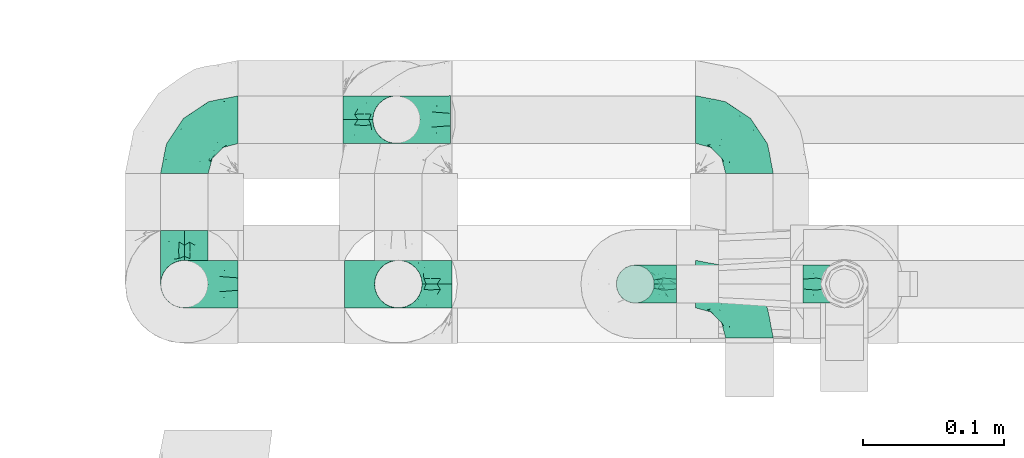
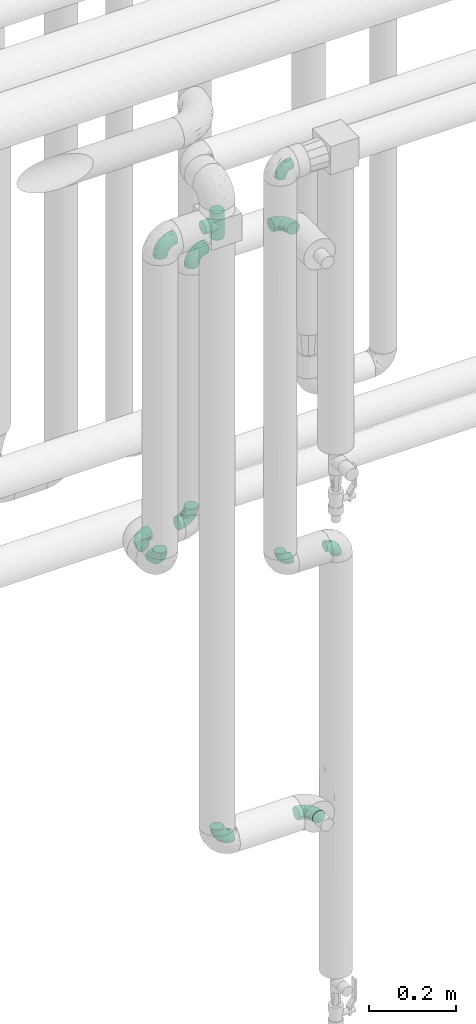
# One storey, part 774 of 827: 12 flow fittings.
"""IFC2X3 building model written with IfcOpenShell, lengths in millimetres."""

from ifc_helpers import new_model, entity, si_unit, converted_unit, derived_unit, direction, frame, origin, place, context, subcontext, project, spatial, faceted_brep, source, transform, mapped, material, type_object, type_shapes, element, save


model = new_model("IFC2X3")

# Units and contexts
model_context = context("Model", 3, precision=0.01, world=origin(), true_north=direction((6.12303176911189e-17, 1.0)))
body_context = subcontext(model_context, "Body", "Model", "MODEL_VIEW")
ifc_project = project(units=[si_unit("LENGTHUNIT", "METRE", prefix="MILLI"), si_unit("AREAUNIT", "SQUARE_METRE"), si_unit("VOLUMEUNIT", "CUBIC_METRE"), converted_unit("PLANEANGLEUNIT", "DEGREE", entity("IfcRatioMeasure", 0.0174532925199433), si_unit("PLANEANGLEUNIT", "RADIAN"), dimensions=[0, 0, 0, 0, 0, 0, 0]), si_unit("MASSUNIT", "GRAM", prefix="KILO"), derived_unit("MASSDENSITYUNIT", [(si_unit("MASSUNIT", "GRAM", prefix="KILO"), 1), (si_unit("LENGTHUNIT", "METRE"), -3)]), derived_unit("MOMENTOFINERTIAUNIT", [(si_unit("LENGTHUNIT", "METRE"), 4)]), si_unit("TIMEUNIT", "SECOND"), si_unit("FREQUENCYUNIT", "HERTZ"), si_unit("THERMODYNAMICTEMPERATUREUNIT", "DEGREE_CELSIUS"), derived_unit("THERMALTRANSMITTANCEUNIT", [(si_unit("MASSUNIT", "GRAM", prefix="KILO"), 1), (si_unit("THERMODYNAMICTEMPERATUREUNIT", "KELVIN"), -1), (si_unit("TIMEUNIT", "SECOND"), -3)]), derived_unit("VOLUMETRICFLOWRATEUNIT", [(si_unit("LENGTHUNIT", "METRE"), 3), (si_unit("TIMEUNIT", "SECOND"), -1)]), derived_unit("MASSFLOWRATEUNIT", [(si_unit("MASSUNIT", "GRAM", prefix="KILO"), 1), (si_unit("TIMEUNIT", "SECOND"), -1)]), derived_unit("ROTATIONALFREQUENCYUNIT", [(si_unit("TIMEUNIT", "SECOND"), -1)]), si_unit("ELECTRICCURRENTUNIT", "AMPERE"), si_unit("ELECTRICVOLTAGEUNIT", "VOLT"), si_unit("POWERUNIT", "WATT"), si_unit("FORCEUNIT", "NEWTON", prefix="KILO"), si_unit("ILLUMINANCEUNIT", "LUX"), si_unit("LUMINOUSFLUXUNIT", "LUMEN"), si_unit("LUMINOUSINTENSITYUNIT", "CANDELA"), derived_unit("USERDEFINED", [(si_unit("MASSUNIT", "GRAM", prefix="KILO"), -1), (si_unit("LENGTHUNIT", "METRE"), -2), (si_unit("TIMEUNIT", "SECOND"), 3), (si_unit("LUMINOUSFLUXUNIT", "LUMEN"), 1)]), derived_unit("LINEARVELOCITYUNIT", [(si_unit("LENGTHUNIT", "METRE"), 1), (si_unit("TIMEUNIT", "SECOND"), -1)]), si_unit("PRESSUREUNIT", "PASCAL"), derived_unit("USERDEFINED", [(si_unit("LENGTHUNIT", "METRE"), -2), (si_unit("MASSUNIT", "GRAM", prefix="KILO"), 1), (si_unit("TIMEUNIT", "SECOND"), -2)]), derived_unit("LINEARFORCEUNIT", [(si_unit("MASSUNIT", "GRAM", prefix="KILO"), 1), (si_unit("LENGTHUNIT", "METRE"), 1), (si_unit("TIMEUNIT", "SECOND"), -2), (si_unit("LENGTHUNIT", "METRE"), -1)]), derived_unit("PLANARFORCEUNIT", [(si_unit("MASSUNIT", "GRAM", prefix="KILO"), 1), (si_unit("LENGTHUNIT", "METRE"), 1), (si_unit("TIMEUNIT", "SECOND"), -2), (si_unit("LENGTHUNIT", "METRE"), -2)])], contexts=[model_context])

# Site, building, storey
site_placement = place(None, origin())
site = spatial("IfcSite", under=ifc_project, at=site_placement, CompositionType="ELEMENT")
building_placement = place(site_placement, origin())
building = spatial("IfcBuilding", under=site, at=building_placement, CompositionType="ELEMENT")
storey_placement = place(building_placement, frame((0.0, 0.0, 28200.0)))
storey = spatial("IfcBuildingStorey", under=building, at=storey_placement, Name="08", CompositionType="ELEMENT", Elevation=28200.0)

# Flow fittings
ifc_material = material()
pipe_fitting_type_1 = type_object("IfcPipeFittingType", Name="ADSK_1", PredefinedType="NOTDEFINED", material=ifc_material)
shared_shape_1 = source(origin(), body_context, "Body", "Brep", [
    faceted_brep([(-38.0, 0.0, -16.85), (-38.0, -4.36, -16.28), (-38.0, -8.43, -14.59), (-38.0, -11.91, -11.91), (-38.0, -14.59, -8.43), (-38.0, -16.28, -4.36), (-38.0, -16.85, 0.0), (-38.0, -16.28, 4.36), (-38.0, -14.59, 8.42), (-38.0, -11.91, 11.91), (-38.0, -8.43, 14.59), (-38.0, -4.36, 16.28), (-38.0, 0.0, 16.85), (-38.0, 4.36, 16.28), (-38.0, 8.42, 14.59), (-38.0, 11.91, 11.91), (-38.0, 14.59, 8.42), (-38.0, 16.28, 4.36), (-38.0, 16.85, 0.0), (-38.0, 16.28, -4.36), (-38.0, 14.59, -8.43), (-38.0, 11.91, -11.91), (-38.0, 8.42, -14.59), (-38.0, 4.36, -16.28), (-4.36, 38.0, -16.28), (-8.42, 38.0, -14.59), (-11.91, 38.0, -11.91), (-14.59, 38.0, -8.43), (-16.28, 38.0, -4.36), (-16.85, 38.0, 0.0), (-16.28, 38.0, 4.36), (-14.59, 38.0, 8.42), (-11.91, 38.0, 11.91), (-8.42, 38.0, 14.59), (-4.36, 38.0, 16.28), (0.0, 38.0, 16.85), (4.36, 38.0, 16.28), (8.43, 38.0, 14.59), (11.91, 38.0, 11.91), (14.59, 38.0, 8.42), (16.28, 38.0, 4.36), (16.85, 38.0, 0.0), (16.28, 38.0, -4.36), (14.59, 38.0, -8.43), (11.91, 38.0, -11.91), (8.43, 38.0, -14.59), (4.36, 38.0, -16.28), (0.0, 38.0, -16.85), (-27.9, -12.9, 9.54), (-27.5, -14.76, 0.0), (-16.53, -9.86, 8.66), (-24.93, -9.38, 12.63), (-29.29, -2.05, 16.58), (-26.82, 2.86, 16.81), (-25.18, -14.43, 5.37), (-4.54, 4.54, 14.04), (-15.36, -3.29, 14.19), (-7.56, -2.74, 10.9), (-28.06, -6.15, 15.21), (9.38, 24.93, 12.63), (-4.71, -4.42, 5.51), (-14.62, -10.99, 4.34), (-8.11, -6.73, 0.0), (-19.46, 0.42, 16.39), (-29.52, 14.25, 10.97), (-26.45, 18.14, 7.62), (-32.84, 15.94, 6.96), (-23.39, 16.22, 12.05), (-11.89, 8.53, 16.79), (-5.59, 13.42, 16.64), (-6.64, 18.62, 16.81), (-32.37, 10.35, 13.72), (-6.4, 32.67, 15.76), (-2.55, 28.48, 16.8), (6.81, 15.56, 11.71), (3.29, 15.36, 14.19), (-29.89, 18.0, 3.79), (-29.34, 6.81, 15.88), (-10.26, 4.27, 15.87), (-2.97, 11.0, 15.66), (2.45, 6.84, 10.65), (-1.8, -0.14, 8.44), (5.0, 5.5, 5.57), (-17.68, 27.4, 7.52), (14.43, 25.18, 5.37), (12.9, 27.9, 9.54), (9.86, 16.53, 8.66), (6.15, 28.06, 15.21), (-17.01, -12.67, 0.0), (2.05, 29.29, 16.58), (14.76, 27.5, 0.0), (10.99, 14.62, 4.34), (12.67, 17.01, 0.0), (-15.84, -6.82, 11.83), (-7.71, 25.61, 16.01), (-22.69, 22.69, 4.1), (-19.68, 27.42, 0.0), (-27.42, 19.68, 0.0), (-18.11, 29.67, 3.72), (-10.87, 29.33, 13.9), (-20.83, 21.64, 8.95), (-18.54, 20.86, 11.76), (-14.08, 30.19, 10.92), (-13.69, 20.27, 14.88), (-20.85, 7.92, 16.51), (-19.04, 4.79, 16.85), (-19.82, 12.26, 15.55), (-19.27, 16.43, 13.96), (-10.72, 19.56, 16.07), (-0.42, 19.46, 16.39), (-25.32, 12.08, 14.15), (-9.04, -6.0, 8.28), (-13.94, 13.94, 16.38), (0.78, -0.78, 0.0), (6.73, 8.11, 0.0), (-9.04, -6.0, -8.28), (-15.9, -7.04, -11.65), (-7.56, -2.74, -10.9), (6.15, 28.06, -15.21), (3.29, 15.36, -14.19), (-0.42, 19.46, -16.39), (-30.19, 14.08, -10.92), (-29.33, 10.87, -13.9), (-25.61, 7.71, -16.01), (-32.67, 6.4, -15.76), (-29.67, 18.11, -3.72), (-18.14, 26.45, -7.62), (-22.69, 22.69, -4.1), (-18.0, 29.89, -3.79), (-25.18, -14.43, -5.37), (-14.62, -10.99, -4.34), (-20.27, 13.69, -14.88), (-15.36, -3.29, -14.19), (-14.25, 29.52, -10.97), (-15.94, 32.84, -6.96), (-24.93, -9.38, -12.63), (-27.9, -12.9, -9.54), (6.81, 15.56, -11.71), (9.38, 24.93, -12.63), (-7.92, 20.85, -16.51), (-4.79, 19.04, -16.85), (-8.53, 11.89, -16.79), (-29.29, -2.05, -16.58), (-13.42, 5.59, -16.64), (-4.27, 10.26, -15.87), (-11.0, 2.97, -15.66), (-16.53, -9.86, -8.66), (-28.48, 2.55, -16.8), (-18.62, 6.64, -16.81), (10.99, 14.62, -4.34), (14.43, 25.18, -5.37), (-12.26, 19.82, -15.55), (-16.43, 19.27, -13.96), (12.9, 27.9, -9.54), (-10.35, 32.37, -13.72), (-6.81, 29.34, -15.88), (2.05, 29.29, -16.58), (-2.86, 26.82, -16.81), (-27.4, 17.68, -7.52), (5.0, 5.5, -5.57), (-16.22, 23.39, -12.05), (-28.06, -6.15, -15.21), (9.86, 16.53, -8.66), (-20.86, 18.54, -11.76), (-21.64, 20.83, -8.95), (-19.56, 10.72, -16.07), (-19.46, 0.42, -16.39), (-12.08, 25.32, -14.15), (-4.54, 4.54, -14.04), (-13.94, 13.94, -16.38), (2.45, 6.84, -10.65), (-4.71, -4.42, -5.51), (-1.8, -0.14, -8.44)], [[[0, 1, 2, 3, 4, 5, 6, 7, 8, 9, 10, 11, 12, 13, 14, 15, 16, 17, 18, 19, 20, 21, 22, 23]], [[24, 25, 26, 27, 28, 29, 30, 31, 32, 33, 34, 35, 36, 37, 38, 39, 40, 41, 42, 43, 44, 45, 46, 47]], [[8, 48, 9]], [[7, 6, 49]], [[48, 50, 51]], [[12, 52, 53]], [[8, 54, 48]], [[7, 54, 8]], [[55, 56, 57]], [[51, 10, 9]], [[51, 58, 10]], [[59, 38, 37]], [[60, 61, 62]], [[58, 56, 63]], [[64, 65, 66]], [[67, 65, 64]], [[68, 69, 70]], [[14, 71, 15]], [[11, 52, 12]], [[34, 72, 73]], [[12, 53, 13]], [[15, 64, 16]], [[74, 59, 75]], [[18, 17, 76]], [[66, 17, 16]], [[77, 13, 53]], [[13, 77, 14]], [[69, 78, 79]], [[80, 81, 82]], [[31, 30, 83]], [[84, 85, 86]], [[59, 87, 75]], [[61, 54, 88]], [[35, 89, 36]], [[84, 40, 39]], [[35, 34, 73]], [[90, 40, 84]], [[39, 38, 85]], [[10, 58, 11]], [[85, 84, 39]], [[91, 84, 86]], [[84, 92, 90]], [[87, 37, 36]], [[93, 56, 51]], [[94, 70, 73]], [[95, 96, 97]], [[84, 91, 92]], [[96, 98, 29]], [[33, 32, 99]], [[76, 95, 97]], [[100, 101, 83]], [[102, 99, 32]], [[65, 95, 76]], [[103, 94, 99]], [[95, 98, 96]], [[72, 99, 94]], [[72, 34, 33]], [[101, 99, 102]], [[7, 49, 54]], [[87, 59, 37]], [[104, 105, 68]], [[106, 103, 107]], [[106, 77, 104]], [[32, 31, 102]], [[94, 103, 108]], [[94, 108, 70]], [[89, 73, 109]], [[71, 64, 15]], [[110, 107, 67]], [[50, 48, 54]], [[51, 9, 48]], [[56, 58, 51]], [[88, 54, 49]], [[52, 58, 63]], [[50, 111, 93]], [[56, 55, 78]], [[38, 59, 85]], [[86, 85, 59]], [[89, 87, 36]], [[41, 40, 90]], [[109, 79, 75]], [[109, 75, 87]], [[75, 55, 80]], [[104, 77, 53]], [[71, 77, 110]], [[31, 83, 102]], [[101, 102, 83]], [[99, 101, 103]], [[106, 107, 110]], [[68, 70, 112]], [[109, 73, 70]], [[68, 112, 104]], [[68, 63, 78]], [[57, 93, 111]], [[80, 55, 57]], [[61, 50, 54]], [[80, 82, 86]], [[81, 57, 111]], [[74, 86, 59]], [[60, 113, 82]], [[82, 114, 91]], [[100, 95, 65]], [[98, 95, 83]], [[73, 89, 35]], [[87, 89, 109]], [[58, 52, 11]], [[53, 52, 63]], [[104, 53, 105]], [[106, 104, 112]], [[18, 76, 97]], [[76, 17, 66]], [[103, 106, 112]], [[77, 106, 110]], [[103, 101, 107]], [[67, 107, 101]], [[67, 101, 100]], [[110, 67, 64]], [[83, 30, 98]], [[29, 98, 30]], [[53, 63, 105]], [[63, 68, 105]], [[56, 78, 63]], [[79, 78, 55]], [[75, 79, 55]], [[69, 79, 109]], [[70, 69, 109]], [[78, 69, 68]], [[62, 113, 60]], [[111, 61, 60]], [[61, 88, 62]], [[86, 82, 91]], [[77, 71, 14]], [[114, 82, 113]], [[114, 92, 91]], [[64, 71, 110]], [[99, 72, 33]], [[73, 72, 94]], [[64, 66, 16]], [[76, 66, 65]], [[95, 100, 83]], [[67, 100, 65]], [[75, 80, 74]], [[80, 86, 74]], [[103, 112, 108]], [[70, 108, 112]], [[50, 93, 51]], [[57, 56, 93]], [[61, 111, 50]], [[81, 111, 60]], [[82, 81, 60]], [[80, 57, 81]], [[115, 116, 117]], [[118, 119, 120]], [[121, 122, 21]], [[123, 124, 122]], [[97, 125, 18]], [[126, 127, 128]], [[127, 97, 96]], [[129, 130, 88]], [[123, 122, 131]], [[116, 132, 117]], [[133, 126, 134]], [[22, 124, 23]], [[3, 135, 136]], [[137, 119, 138]], [[129, 88, 49]], [[139, 140, 141]], [[4, 3, 136]], [[45, 118, 46]], [[142, 1, 0]], [[143, 144, 145]], [[4, 129, 5]], [[129, 136, 146]], [[147, 0, 23]], [[22, 21, 122]], [[127, 125, 97]], [[123, 148, 147]], [[96, 128, 127]], [[149, 150, 92]], [[29, 28, 128]], [[151, 131, 152]], [[26, 133, 27]], [[153, 44, 43]], [[135, 3, 2]], [[26, 25, 154]], [[155, 25, 24]], [[47, 156, 157]], [[47, 46, 156]], [[20, 19, 158]], [[159, 149, 114]], [[126, 133, 160]], [[141, 143, 148]], [[45, 138, 118]], [[161, 135, 2]], [[155, 24, 157]], [[23, 124, 147]], [[115, 146, 116]], [[44, 153, 138]], [[138, 45, 44]], [[153, 162, 138]], [[161, 2, 1]], [[41, 90, 42]], [[130, 129, 146]], [[49, 5, 129]], [[42, 150, 43]], [[163, 122, 121]], [[47, 157, 24]], [[135, 161, 132]], [[134, 28, 27]], [[42, 90, 150]], [[164, 163, 158]], [[151, 155, 139]], [[21, 20, 121]], [[123, 131, 165]], [[123, 165, 148]], [[142, 147, 166]], [[154, 133, 26]], [[167, 152, 160]], [[146, 136, 135]], [[6, 5, 49]], [[129, 4, 136]], [[142, 161, 1]], [[166, 145, 132]], [[166, 132, 161]], [[132, 168, 117]], [[43, 150, 153]], [[92, 150, 90]], [[162, 153, 150]], [[119, 118, 138]], [[156, 118, 120]], [[137, 138, 162]], [[119, 168, 144]], [[139, 155, 157]], [[154, 155, 167]], [[20, 158, 121]], [[163, 121, 158]], [[122, 163, 131]], [[151, 152, 167]], [[141, 148, 169]], [[166, 147, 148]], [[141, 169, 139]], [[141, 120, 144]], [[168, 170, 117]], [[159, 171, 172]], [[115, 172, 171]], [[171, 62, 130]], [[119, 170, 168]], [[170, 162, 159]], [[149, 162, 150]], [[113, 171, 159]], [[164, 127, 126]], [[125, 127, 158]], [[147, 142, 0]], [[161, 142, 166]], [[118, 156, 46]], [[157, 156, 120]], [[139, 157, 140]], [[151, 139, 169]], [[29, 128, 96]], [[128, 28, 134]], [[131, 151, 169]], [[155, 151, 167]], [[131, 163, 152]], [[160, 152, 163]], [[160, 163, 164]], [[167, 160, 133]], [[158, 19, 125]], [[18, 125, 19]], [[157, 120, 140]], [[120, 141, 140]], [[119, 144, 120]], [[145, 144, 168]], [[132, 145, 168]], [[143, 145, 166]], [[148, 143, 166]], [[144, 143, 141]], [[115, 130, 146]], [[114, 113, 159]], [[62, 171, 113]], [[62, 88, 130]], [[159, 162, 149]], [[149, 92, 114]], [[155, 154, 25]], [[133, 154, 167]], [[122, 124, 22]], [[147, 124, 123]], [[133, 134, 27]], [[128, 134, 126]], [[127, 164, 158]], [[160, 164, 126]], [[162, 170, 137]], [[170, 119, 137]], [[131, 169, 165]], [[148, 165, 169]], [[146, 135, 116]], [[132, 116, 135]], [[172, 115, 117]], [[130, 115, 171]], [[117, 170, 172]], [[159, 172, 170]]]),
])
type_shapes(pipe_fitting_type_1, [shared_shape_1])
for number, where, z_axis, x_axis, name in (
    (1, (59025.14, 15444.21, 870.51), (0.0, -1.0, 0.0), (0.0, 0.0, -1.0), "ADSK_1"),
    (2, (58873.89, 15444.21, 2600.0), (0.0, -1.0, 0.0), (-1.0, 0.0, 0.0), "ADSK_1"),
    (3, (58873.89, 15444.21, 1700.53), (1.0, 0.0, 0.0), (0.0, 0.0, -1.0), "ADSK_1"),
    (4, (58873.89, 15560.47, 1700.53), (0.0, 0.0, 1.0), (-1.0, 0.0, 0.0), "ADSK_1"),
    (5, (59023.89, 15560.47, 1700.53), (0.0, -1.0, 0.0), (1.0, 0.0, 0.0), "ADSK_1"),
    (6, (59023.89, 15560.52, 2450.53), (0.0, 0.999998950130107, -0.00144904750950451), (0.0, 0.00144904750950451, 0.999998950130107), "ADSK_1"),
    (7, (59273.36, 15560.52, 2450.53), (0.0, 0.0, 1.0), (0.0, 1.0, 0.0), "ADSK_1"),
    (8, (59273.36, 15444.21, 870.51), (0.0, 0.0, 1.0), (0.0, 1.0, 0.0), "ADSK_1"),
):
    element("IfcFlowFitting", number, at=place(storey_placement, frame(where, z_axis=z_axis, x_axis=x_axis)), inside=storey, type_object=pipe_fitting_type_1, material=ifc_material, Name=name, ObjectType="ADSK_1", context=body_context, shape_type="MappedRepresentation", body=[
        mapped(shared_shape_1, transform((0.0, 0.0, 0.0), scale=1.0)),
    ])
pipe_fitting_type_2 = type_object("IfcPipeFittingType", Name="ADSK_1", PredefinedType="NOTDEFINED", material=ifc_material)
shared_shape_2 = source(origin(), body_context, "Body", "Brep", [
    faceted_brep([(-38.0, 0.0, -16.85), (-38.0, -4.36, -16.28), (-38.0, -8.43, -14.59), (-38.0, -11.91, -11.91), (-38.0, -14.59, -8.43), (-38.0, -16.28, -4.36), (-38.0, -16.85, 0.0), (-38.0, -16.28, 4.36), (-38.0, -14.59, 8.42), (-38.0, -11.91, 11.91), (-38.0, -8.43, 14.59), (-38.0, -4.36, 16.28), (-38.0, 0.0, 16.85), (-38.0, 4.36, 16.28), (-38.0, 8.42, 14.59), (-38.0, 11.91, 11.91), (-38.0, 14.59, 8.42), (-38.0, 16.28, 4.36), (-38.0, 16.85, 0.0), (-38.0, 16.28, -4.36), (-38.0, 14.59, -8.43), (-38.0, 11.91, -11.91), (-38.0, 8.42, -14.59), (-38.0, 4.36, -16.28), (38.0, 4.36, -16.28), (38.0, 8.42, -14.59), (38.0, 11.91, -11.91), (38.0, 14.59, -8.43), (38.0, 16.28, -4.36), (38.0, 16.85, 0.0), (38.0, 16.28, 4.36), (38.0, 14.59, 8.42), (38.0, 11.91, 11.91), (38.0, 8.42, 14.59), (38.0, 4.36, 16.28), (38.0, 0.0, 16.85), (38.0, -4.36, 16.28), (38.0, -8.43, 14.59), (38.0, -11.91, 11.91), (38.0, -14.59, 8.42), (38.0, -16.28, 4.36), (38.0, -16.85, 0.0), (38.0, -16.28, -4.36), (38.0, -14.59, -8.43), (38.0, -11.91, -11.91), (38.0, -8.43, -14.59), (38.0, -4.36, -16.28), (38.0, 0.0, -16.85), (16.24, -16.24, 4.5), (16.85, -16.85, 0.0), (-16.85, -16.85, 0.0), (14.58, -14.58, 8.44), (9.44, -9.44, 13.95), (12.23, -12.23, 11.59), (-16.24, -16.24, 4.5), (-14.58, -14.58, 8.44), (-12.23, -12.23, 11.59), (-9.44, -9.44, 13.95), (-6.41, -6.41, 15.58), (6.41, -6.41, 15.58), (3.24, -3.24, 16.54), (0.0, 0.0, 16.85), (-3.24, -3.24, 16.54), (3.24, -3.24, -16.54), (0.0, 0.0, -16.85), (-3.24, -3.24, -16.54), (-6.41, -6.41, -15.58), (6.41, -6.41, -15.58), (9.44, -9.44, -13.95), (12.23, -12.23, -11.59), (14.58, -14.58, -8.44), (16.24, -16.24, -4.5), (-9.44, -9.44, -13.95), (-12.23, -12.23, -11.59), (-16.24, -16.24, -4.5), (-14.58, -14.58, -8.44), (4.36, -38.0, -16.28), (8.43, -38.0, -14.59), (11.91, -38.0, -11.91), (14.59, -38.0, -8.43), (16.28, -38.0, -4.36), (16.85, -38.0, 0.0), (16.28, -38.0, 4.36), (14.59, -38.0, 8.42), (11.91, -38.0, 11.91), (8.43, -38.0, 14.59), (4.36, -38.0, 16.28), (0.0, -38.0, 16.85), (-4.36, -38.0, 16.28), (-8.42, -38.0, 14.59), (-11.91, -38.0, 11.91), (-14.59, -38.0, 8.42), (-16.28, -38.0, 4.36), (-16.85, -38.0, 0.0), (-16.28, -38.0, -4.36), (-14.59, -38.0, -8.43), (-11.91, -38.0, -11.91), (-8.42, -38.0, -14.59), (-4.36, -38.0, -16.28), (0.0, -38.0, -16.85)], [[[0, 1, 2, 3, 4, 5, 6, 7, 8, 9, 10, 11, 12, 13, 14, 15, 16, 17, 18, 19, 20, 21, 22, 23]], [[24, 25, 26, 27, 28, 29, 30, 31, 32, 33, 34, 35, 36, 37, 38, 39, 40, 41, 42, 43, 44, 45, 46, 47]], [[40, 39, 48]], [[41, 40, 49]], [[50, 7, 6]], [[49, 40, 48]], [[39, 51, 48]], [[38, 37, 52]], [[51, 39, 53]], [[52, 53, 38]], [[53, 39, 38]], [[50, 54, 7]], [[7, 54, 8]], [[54, 55, 8]], [[56, 57, 9]], [[9, 8, 56]], [[9, 57, 10]], [[56, 8, 55]], [[10, 57, 58]], [[52, 37, 59]], [[60, 35, 61]], [[62, 61, 12]], [[59, 36, 60]], [[36, 59, 37]], [[60, 36, 35]], [[61, 35, 34, 13, 12]], [[31, 30, 17, 16]], [[15, 14, 33, 32]], [[16, 15, 32, 31]], [[34, 33, 14, 13]], [[18, 17, 30, 29]], [[62, 11, 58]], [[11, 62, 12]], [[58, 11, 10]], [[26, 21, 20, 27]], [[28, 19, 18, 29]], [[28, 27, 20, 19]], [[22, 21, 26, 25]], [[47, 46, 63]], [[47, 64, 0, 23, 24]], [[64, 47, 63]], [[0, 64, 65]], [[25, 24, 23, 22]], [[65, 66, 1]], [[0, 65, 1]], [[66, 2, 1]], [[63, 46, 67]], [[45, 44, 68]], [[69, 68, 44]], [[43, 70, 69]], [[69, 44, 43]], [[45, 68, 67]], [[42, 41, 49]], [[5, 50, 6]], [[42, 71, 43]], [[71, 42, 49]], [[43, 71, 70]], [[72, 2, 66]], [[72, 3, 2]], [[3, 72, 73]], [[3, 73, 4]], [[74, 50, 5]], [[75, 74, 4]], [[74, 5, 4]], [[75, 4, 73]], [[45, 67, 46]], [[76, 77, 78, 79, 80, 81, 82, 83, 84, 85, 86, 87, 88, 89, 90, 91, 92, 93, 94, 95, 96, 97, 98, 99]], [[50, 93, 92]], [[54, 50, 92]], [[90, 89, 57]], [[56, 91, 90]], [[54, 92, 91]], [[58, 89, 88]], [[55, 54, 91]], [[56, 55, 91]], [[58, 57, 89]], [[87, 61, 62]], [[58, 88, 62]], [[56, 90, 57]], [[62, 88, 87]], [[60, 87, 86]], [[85, 59, 86]], [[83, 82, 48]], [[53, 84, 83]], [[52, 85, 84]], [[49, 82, 81]], [[59, 60, 86]], [[52, 59, 85]], [[49, 48, 82]], [[51, 53, 83]], [[48, 51, 83]], [[52, 84, 53]], [[87, 60, 61]], [[81, 80, 49]], [[71, 49, 80]], [[69, 79, 78]], [[78, 77, 68]], [[71, 80, 79]], [[67, 77, 76]], [[70, 71, 79]], [[69, 70, 79]], [[67, 68, 77]], [[99, 64, 63]], [[67, 76, 63]], [[69, 78, 68]], [[63, 76, 99]], [[65, 99, 98]], [[97, 66, 98]], [[95, 94, 74]], [[73, 96, 95]], [[72, 97, 96]], [[50, 94, 93]], [[66, 65, 98]], [[72, 66, 97]], [[50, 74, 94]], [[75, 73, 95]], [[74, 75, 95]], [[72, 96, 73]], [[99, 65, 64]]]),
])
type_shapes(pipe_fitting_type_2, [shared_shape_2])
flow_fitting_placement = place(storey_placement, frame((59025.14, 15444.21, 2600.0), z_axis=(0.0, 1.0, 0.0), x_axis=(0.0, 0.0, 1.0)))
element("IfcFlowFitting", 9, at=flow_fitting_placement, inside=storey, type_object=pipe_fitting_type_2, material=ifc_material, Name="ADSK_1", ObjectType="ADSK_1", context=body_context, shape_type="MappedRepresentation", body=[
    mapped(shared_shape_2, transform((0.0, 0.0, 0.0), scale=1.0)),
])
pipe_fitting_type_3 = type_object("IfcPipeFittingType", Name="ADSK_1", PredefinedType="NOTDEFINED", material=ifc_material)
shared_shape_3 = source(origin(), body_context, "Body", "Brep", [
    faceted_brep([(-29.1, 0.0, -13.45), (-29.1, -3.48, -12.99), (-29.1, -6.73, -11.65), (-29.1, -9.51, -9.51), (-29.1, -11.65, -6.73), (-29.1, -12.99, -3.48), (-29.1, -13.45, 0.0), (-29.1, -12.99, 3.48), (-29.1, -11.65, 6.72), (-29.1, -9.51, 9.51), (-29.1, -6.73, 11.65), (-29.1, -3.48, 12.99), (-29.1, 0.0, 13.45), (-29.1, 3.48, 12.99), (-29.1, 6.72, 11.65), (-29.1, 9.51, 9.51), (-29.1, 11.65, 6.72), (-29.1, 12.99, 3.48), (-29.1, 13.45, 0.0), (-29.1, 12.99, -3.48), (-29.1, 11.65, -6.73), (-29.1, 9.51, -9.51), (-29.1, 6.72, -11.65), (-29.1, 3.48, -12.99), (-3.48, 29.1, -12.99), (-6.72, 29.1, -11.65), (-9.51, 29.1, -9.51), (-11.65, 29.1, -6.73), (-12.99, 29.1, -3.48), (-13.45, 29.1, 0.0), (-12.99, 29.1, 3.48), (-11.65, 29.1, 6.72), (-9.51, 29.1, 9.51), (-6.72, 29.1, 11.65), (-3.48, 29.1, 12.99), (0.0, 29.1, 13.45), (3.48, 29.1, 12.99), (6.73, 29.1, 11.65), (9.51, 29.1, 9.51), (11.65, 29.1, 6.72), (12.99, 29.1, 3.48), (13.45, 29.1, 0.0), (12.99, 29.1, -3.48), (11.65, 29.1, -6.73), (9.51, 29.1, -9.51), (6.73, 29.1, -11.65), (3.48, 29.1, -12.99), (0.0, 29.1, -13.45), (-19.62, -11.66, 4.28), (-21.41, -10.36, 7.6), (-16.26, -10.01, 0.0), (-12.48, -9.76, 2.75), (-10.66, 15.6, 11.91), (-15.27, 9.55, 12.42), (-10.71, 10.71, 13.09), (-0.04, 0.04, 0.0), (0.49, -0.45, 4.38), (-3.67, -4.15, 4.26), (-22.68, -11.73, 0.0), (-21.45, -4.97, 12.13), (-11.59, -2.84, 11.28), (-14.77, 0.17, 13.07), (-19.08, -7.58, 10.06), (-22.36, -1.69, 13.23), (-20.49, 2.21, 13.42), (-7.82, -7.75, 0.0), (-5.53, -2.55, 8.58), (-1.33, -0.87, 6.53), (-1.15, 1.15, 8.49), (-22.46, 5.38, 12.69), (-14.04, 21.05, 6.04), (-3.19, 3.19, 11.14), (-5.08, 25.05, 12.59), (-1.97, 21.79, 13.41), (-22.68, 11.31, 8.78), (-18.16, 12.64, 9.68), (-20.46, 14.33, 6.11), (-4.13, 10.11, 13.26), (-7.66, 3.08, 12.63), (-2.02, 8.24, 12.45), (-24.91, 8.22, 10.95), (-5.08, 14.28, 13.42), (-8.96, 6.48, 13.4), (-19.7, 16.14, 3.1), (-18.03, 18.03, 0.0), (-23.05, 15.96, 0.0), (-25.26, 12.69, 5.56), (4.97, 21.45, 12.13), (7.58, 19.08, 10.06), (1.69, 22.36, 13.23), (10.36, 21.41, 7.6), (8.11, 12.69, 6.86), (11.66, 19.62, 4.28), (-6.03, 19.65, 12.79), (9.76, 12.48, 2.75), (10.01, 16.26, 0.0), (-14.58, 16.06, 9.44), (-11.19, 23.14, 8.74), (-16.29, 16.8, 7.24), (-11.99, -5.68, 9.36), (-15.42, 20.78, 3.08), (5.79, 12.02, 9.27), (2.84, 11.59, 11.28), (2.55, 5.53, 8.58), (-15.74, 23.57, 0.0), (-15.96, 23.05, 0.0), (-24.62, 13.88, 2.39), (-8.61, 22.49, 11.12), (-14.98, 12.8, 11.14), (11.73, 22.68, 0.0), (-12.69, -8.11, 6.86), (7.75, 7.82, 0.0), (-15.98, 6.12, 13.19), (-14.48, 3.64, 13.45), (-19.6, 9.46, 11.31), (-8.3, 15.02, 12.85), (-0.17, 14.77, 13.07), (-6.9, -5.2, 6.52), (7.5, 8.93, 4.46), (5.22, 6.95, 6.56), (-8.85, -7.47, 4.42), (3.86, 3.93, 0.0), (4.18, 3.75, 4.31), (-23.57, 15.74, 0.0), (-3.93, -3.86, 0.0), (-21.79, 1.97, -13.41), (-11.31, 22.68, -8.78), (-14.33, 20.46, -6.11), (-12.69, 25.26, -5.56), (4.97, 21.45, -12.13), (2.84, 11.59, -11.28), (-0.17, 14.77, -13.07), (-25.05, 5.08, -12.59), (-16.8, 16.29, -7.24), (-20.78, 15.42, -3.08), (-16.14, 19.7, -3.1), (-12.02, -5.79, -9.27), (-11.59, -2.84, -11.28), (-5.53, -2.55, -8.58), (-23.14, 11.19, -8.74), (-22.49, 8.61, -11.12), (-1.33, -0.87, -6.53), (-3.67, -4.15, -4.26), (-6.9, -5.2, -6.52), (-19.65, 6.03, -12.79), (-15.6, 10.66, -11.91), (-14.28, 5.08, -13.42), (-10.71, 10.71, -13.09), (-6.48, 8.96, -13.4), (-19.62, -11.66, -4.28), (-21.41, -10.36, -7.6), (-12.48, -9.76, -2.75), (11.66, 19.62, -4.28), (-12.69, -8.11, -6.86), (-22.36, -1.69, -13.23), (-16.06, 14.58, -9.44), (5.68, 11.99, -9.36), (7.58, 19.08, -10.06), (-19.08, -7.58, -10.06), (-21.45, -4.97, -12.13), (-9.55, 15.27, -12.42), (-12.8, 14.98, -11.14), (-8.22, 24.91, -10.95), (10.36, 21.41, -7.6), (-5.38, 22.46, -12.69), (1.69, 22.36, -13.23), (-2.21, 20.49, -13.42), (-12.64, 18.16, -9.68), (-21.05, 14.04, -6.04), (9.76, 12.48, -2.75), (-10.11, 4.13, -13.26), (-3.08, 7.66, -12.63), (-8.24, 2.02, -12.45), (-13.88, 24.62, -2.39), (8.11, 12.69, -6.86), (-6.12, 15.98, -13.19), (-3.64, 14.48, -13.45), (-9.46, 19.6, -11.31), (-15.02, 8.3, -12.85), (-14.77, 0.17, -13.07), (-3.19, 3.19, -11.14), (5.22, 6.95, -6.56), (2.55, 5.53, -8.58), (0.49, -0.45, -4.38), (4.18, 3.75, -4.31), (-8.85, -7.47, -4.42), (-1.15, 1.15, -8.49), (7.5, 8.93, -4.46)], [[[0, 1, 2, 3, 4, 5, 6, 7, 8, 9, 10, 11, 12, 13, 14, 15, 16, 17, 18, 19, 20, 21, 22, 23]], [[24, 25, 26, 27, 28, 29, 30, 31, 32, 33, 34, 35, 36, 37, 38, 39, 40, 41, 42, 43, 44, 45, 46, 47]], [[48, 49, 8]], [[48, 50, 51]], [[52, 53, 54]], [[55, 56, 57]], [[49, 9, 8]], [[58, 48, 7]], [[59, 60, 61]], [[62, 10, 9]], [[62, 59, 10]], [[12, 63, 64]], [[51, 50, 65]], [[66, 67, 68]], [[12, 11, 63]], [[69, 14, 13]], [[31, 30, 70]], [[66, 71, 60]], [[34, 72, 73]], [[74, 75, 76]], [[77, 78, 79]], [[14, 80, 15]], [[16, 15, 74]], [[81, 54, 82]], [[83, 84, 85]], [[74, 76, 86]], [[37, 87, 88]], [[88, 38, 37]], [[36, 35, 89]], [[90, 91, 92]], [[93, 81, 73]], [[35, 34, 73]], [[10, 59, 11]], [[92, 94, 95]], [[96, 97, 98]], [[90, 92, 39]], [[99, 60, 62]], [[40, 39, 92]], [[87, 37, 36]], [[100, 84, 83]], [[50, 48, 58]], [[100, 83, 98]], [[101, 102, 103]], [[104, 105, 84, 100, 29]], [[48, 8, 7]], [[86, 17, 16]], [[106, 18, 17]], [[32, 97, 107]], [[53, 52, 108]], [[52, 93, 107]], [[97, 96, 107]], [[72, 107, 93]], [[72, 34, 33]], [[92, 109, 40]], [[33, 32, 107]], [[69, 13, 64]], [[88, 87, 102]], [[12, 64, 13]], [[49, 110, 62]], [[39, 38, 90]], [[95, 94, 111]], [[112, 113, 82]], [[53, 69, 112]], [[80, 74, 15]], [[114, 108, 75]], [[32, 31, 97]], [[115, 52, 54]], [[93, 115, 81]], [[89, 73, 116]], [[106, 76, 83]], [[106, 83, 85]], [[83, 76, 98]], [[100, 30, 29]], [[60, 59, 62]], [[63, 59, 61]], [[110, 117, 99]], [[60, 71, 78]], [[89, 87, 36]], [[116, 79, 102]], [[116, 102, 87]], [[102, 71, 103]], [[110, 49, 48]], [[62, 9, 49]], [[38, 88, 90]], [[91, 90, 88]], [[112, 69, 64]], [[80, 69, 114]], [[111, 94, 118]], [[119, 101, 103]], [[117, 66, 99]], [[117, 120, 57]], [[119, 91, 101]], [[66, 68, 71]], [[66, 117, 67]], [[121, 111, 122, 55]], [[56, 55, 122]], [[31, 70, 97]], [[97, 70, 98]], [[107, 96, 52]], [[53, 108, 114]], [[112, 82, 54]], [[116, 73, 81]], [[78, 82, 61]], [[81, 82, 77]], [[73, 89, 35]], [[87, 89, 116]], [[59, 63, 11]], [[64, 63, 61]], [[112, 64, 113]], [[53, 112, 54]], [[7, 6, 58]], [[109, 92, 95]], [[109, 41, 40]], [[69, 53, 114]], [[52, 96, 108]], [[75, 108, 96]], [[75, 96, 98]], [[114, 75, 74]], [[64, 61, 113]], [[61, 82, 113]], [[91, 88, 101]], [[110, 48, 51]], [[92, 91, 94]], [[91, 119, 118]], [[106, 85, 123, 18]], [[106, 17, 86]], [[60, 78, 61]], [[79, 78, 71]], [[102, 79, 71]], [[77, 79, 116]], [[81, 77, 116]], [[78, 77, 82]], [[69, 80, 14]], [[74, 80, 114]], [[74, 86, 16]], [[106, 86, 76]], [[107, 72, 33]], [[73, 72, 93]], [[98, 70, 100]], [[75, 98, 76]], [[30, 100, 70]], [[110, 99, 62]], [[66, 60, 99]], [[120, 110, 51]], [[67, 117, 57]], [[57, 56, 67]], [[67, 122, 119]], [[110, 120, 117]], [[65, 120, 51]], [[57, 65, 124, 55]], [[122, 67, 56]], [[67, 103, 68]], [[71, 68, 103]], [[65, 57, 120]], [[102, 101, 88]], [[67, 119, 103]], [[118, 119, 122]], [[118, 122, 111]], [[91, 118, 94]], [[81, 115, 54]], [[93, 52, 115]], [[23, 125, 0]], [[126, 127, 128]], [[129, 130, 131]], [[23, 22, 132]], [[133, 134, 135]], [[136, 137, 138]], [[21, 139, 140]], [[141, 142, 143]], [[144, 140, 145]], [[143, 136, 138]], [[146, 147, 148]], [[144, 132, 140]], [[5, 4, 149]], [[4, 3, 150]], [[45, 129, 46]], [[151, 50, 149]], [[152, 43, 42]], [[42, 41, 109]], [[150, 149, 4]], [[153, 149, 150]], [[154, 1, 0]], [[139, 155, 140]], [[156, 130, 157]], [[149, 58, 5]], [[18, 123, 85, 84, 134]], [[158, 159, 137]], [[84, 105, 135]], [[160, 145, 161]], [[143, 153, 136]], [[27, 26, 126]], [[25, 162, 26]], [[152, 163, 43]], [[25, 24, 164]], [[47, 165, 166]], [[158, 3, 2]], [[167, 127, 126]], [[20, 19, 168]], [[47, 46, 165]], [[44, 157, 45]], [[23, 132, 125]], [[44, 43, 163]], [[158, 2, 159]], [[47, 166, 24]], [[129, 45, 157]], [[164, 24, 166]], [[134, 84, 135]], [[95, 169, 152]], [[22, 21, 140]], [[144, 146, 125]], [[109, 152, 42]], [[95, 152, 109]], [[170, 171, 172]], [[155, 139, 133]], [[28, 27, 128]], [[159, 2, 1]], [[173, 29, 28]], [[50, 151, 65]], [[169, 95, 111]], [[163, 174, 157]], [[175, 176, 148]], [[160, 164, 175]], [[162, 126, 26]], [[177, 161, 167]], [[21, 20, 139]], [[144, 145, 178]], [[144, 178, 146]], [[154, 125, 179]], [[173, 127, 135]], [[173, 135, 105]], [[135, 127, 133]], [[134, 19, 18]], [[154, 159, 1]], [[179, 172, 137]], [[179, 137, 159]], [[137, 180, 138]], [[130, 129, 157]], [[165, 129, 131]], [[174, 181, 156]], [[130, 180, 171]], [[3, 158, 150]], [[153, 150, 158]], [[174, 163, 152]], [[157, 44, 163]], [[175, 164, 166]], [[162, 164, 177]], [[130, 182, 180]], [[181, 141, 182]], [[55, 183, 184]], [[65, 151, 185]], [[183, 55, 142]], [[156, 181, 182]], [[180, 182, 186]], [[181, 187, 184]], [[65, 142, 55, 124]], [[20, 168, 139]], [[139, 168, 133]], [[140, 155, 145]], [[160, 161, 177]], [[175, 148, 147]], [[179, 125, 146]], [[171, 148, 131]], [[146, 148, 170]], [[125, 154, 0]], [[159, 154, 179]], [[129, 165, 46]], [[166, 165, 131]], [[175, 166, 176]], [[160, 175, 147]], [[58, 149, 50]], [[58, 6, 5]], [[145, 160, 147]], [[164, 160, 177]], [[145, 155, 161]], [[167, 161, 155]], [[167, 155, 133]], [[177, 167, 126]], [[166, 131, 176]], [[131, 148, 176]], [[149, 153, 151]], [[153, 143, 185]], [[145, 147, 178]], [[174, 152, 169]], [[173, 105, 104, 29]], [[173, 28, 128]], [[130, 171, 131]], [[172, 171, 180]], [[137, 172, 180]], [[170, 172, 179]], [[146, 170, 179]], [[171, 170, 148]], [[164, 162, 25]], [[126, 162, 177]], [[126, 128, 27]], [[173, 128, 127]], [[140, 132, 22]], [[125, 132, 144]], [[133, 168, 134]], [[167, 133, 127]], [[19, 134, 168]], [[153, 158, 136]], [[137, 136, 158]], [[141, 143, 138]], [[185, 143, 142]], [[186, 141, 138]], [[183, 142, 141]], [[185, 142, 65]], [[153, 185, 151]], [[180, 186, 138]], [[182, 141, 186]], [[141, 184, 183]], [[184, 111, 121, 55]], [[174, 156, 157]], [[182, 130, 156]], [[187, 174, 169]], [[141, 181, 184]], [[174, 187, 181]], [[111, 187, 169]], [[111, 184, 187]], [[146, 178, 147]]]),
])
type_shapes(pipe_fitting_type_3, [shared_shape_3])
for number, where, z_axis, x_axis, name in (
    (10, (59192.64, 15444.21, 1593.05), (0.0, 1.0, 0.0), (-1.0, 0.0, 0.0), "ADSK_1"),
    (11, (59192.64, 15444.21, 2700.0), (0.0, -1.0, 0.0), (-1.0, 0.0, 0.0), "ADSK_1"),
    (12, (59340.46, 15444.21, 1593.05), (0.0, 1.0, 0.0), (1.0, 0.0, 0.0), "ADSK_1"),
):
    element("IfcFlowFitting", number, at=place(storey_placement, frame(where, z_axis=z_axis, x_axis=x_axis)), inside=storey, type_object=pipe_fitting_type_3, material=ifc_material, Name=name, ObjectType="ADSK_1", context=body_context, shape_type="MappedRepresentation", body=[
        mapped(shared_shape_3, transform((0.0, 0.0, 0.0), scale=1.0)),
    ])

save(model, "model.ifc")
